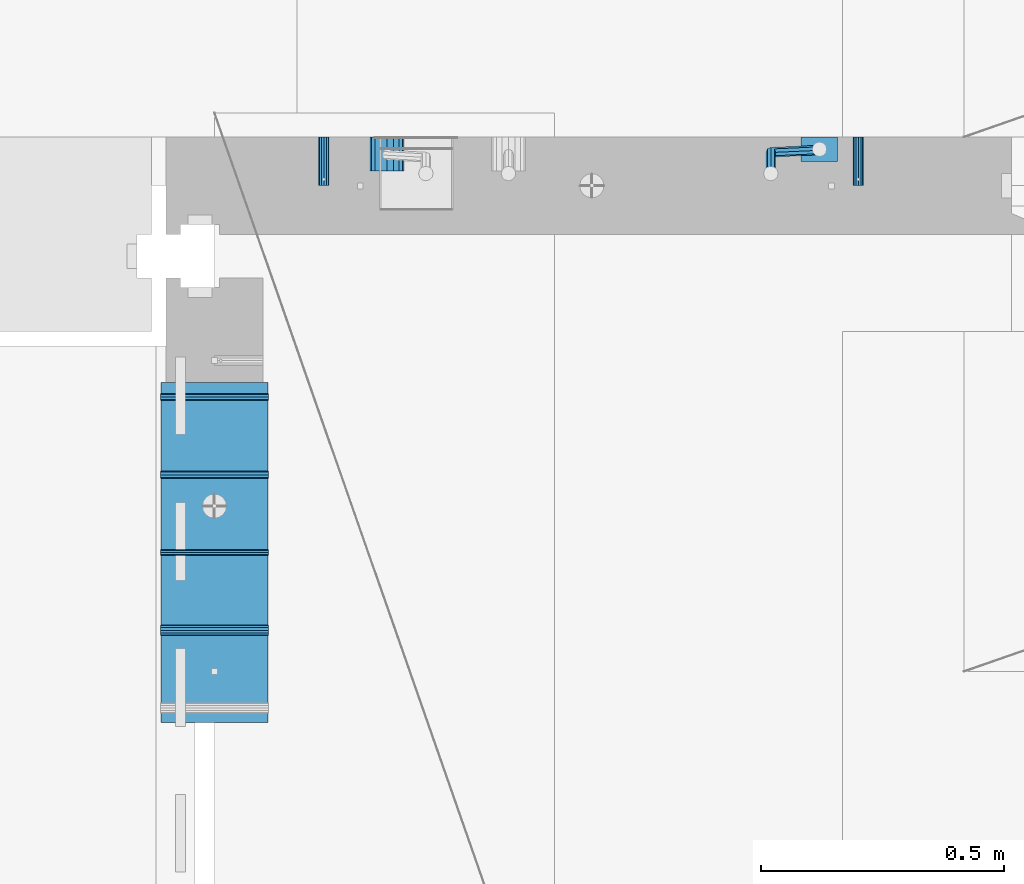
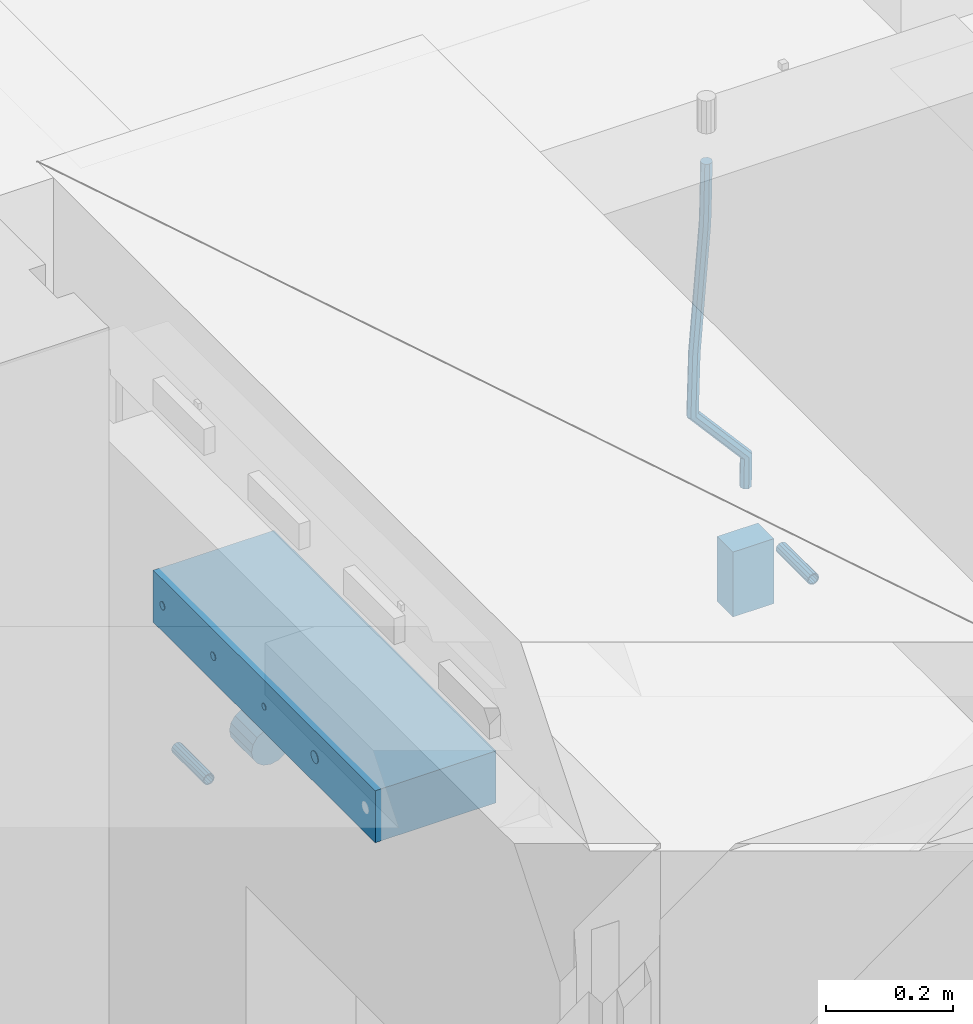
# One storey, part 143 of 325: 10 beams, 4 elements without a shape of their own.
"""IFC2X3 building model written with IfcOpenShell, lengths in millimetres."""

from ifc_helpers import new_model, si_unit, frame, origin_with_axes, place, context, subcontext, project, spatial, faceted_brep, material, type_object, element, aggregate, save


model = new_model("IFC2X3")

# Units and contexts
model_context = context("Model", 3, precision=1e-05, world=origin_with_axes())
body_context = subcontext(model_context, "Body", "Model", "MODEL_VIEW")
ifc_project = project(units=[si_unit("LENGTHUNIT", "METRE", prefix="MILLI"), si_unit("AREAUNIT", "SQUARE_METRE"), si_unit("VOLUMEUNIT", "CUBIC_METRE"), si_unit("MASSUNIT", "GRAM", prefix="KILO"), si_unit("TIMEUNIT", "SECOND"), si_unit("PLANEANGLEUNIT", "RADIAN"), si_unit("SOLIDANGLEUNIT", "STERADIAN"), si_unit("THERMODYNAMICTEMPERATUREUNIT", "DEGREE_CELSIUS"), si_unit("LUMINOUSINTENSITYUNIT", "LUMEN")], contexts=[model_context])

# Site, building, storey
site_placement = place(None, origin_with_axes())
site = spatial("IfcSite", under=ifc_project, at=site_placement, CompositionType="ELEMENT")
building_placement = place(site_placement, origin_with_axes())
building = spatial("IfcBuilding", under=site, at=building_placement, CompositionType="ELEMENT")
storey_placement = place(building_placement, origin_with_axes())
storey = spatial("IfcBuildingStorey", under=building, at=storey_placement, Name="1", CompositionType="ELEMENT", Elevation=0.0)

# Assemblies, beams
assembly_1_placement = place(storey_placement, origin_with_axes())
assembly_1 = element("IfcElementAssembly", 1, at=assembly_1_placement, inside=storey, AssemblyPlace="NOTDEFINED", PredefinedType="REINFORCEMENT_UNIT")
assembly_2_placement = place(assembly_1_placement, origin_with_axes())
assembly_2 = element("IfcElementAssembly", 2, at=assembly_2_placement, Name="Steel Assembly", AssemblyPlace="NOTDEFINED", PredefinedType="RIGID_FRAME")
ifc_material_1 = material(Name="STEEL/Steel_Undefined")
beam_type_1 = type_object("IfcBeamType", PredefinedType="NOTDEFINED")
beam_1_placement = place(assembly_2_placement, frame((26834.9999668009, 17080.0, 83555.0), z_axis=(-1.0, 3.00000001838171e-08, 0.0), x_axis=(0.0, -1.0, 0.0)))
beam_1 = element("IfcBeam", 3, at=beam_1_placement, type_object=beam_type_1, material=ifc_material_1, Name="M16", context=body_context, shape_type="Brep", body=[
    faceted_brep([(0.0, -8.49999999999272, -1.45519152283669e-11), (0.0, -7.36121593215648, 4.24999999998545), (100.000000000262, -7.36121593215648, 4.24999999998545), (100.000000000262, -8.49999999999272, -1.45519152283669e-11), (0.0, -4.24999999998545, 7.36121593216376), (100.000000000262, -4.24999999998545, 7.36121593216376), (0.0, 1.45519152283669e-11, 8.49999999998545), (100.000000000262, 1.45519152283669e-11, 8.49999999998545), (0.0, 4.25000000001455, 7.36121593216376), (100.000000000262, 4.25000000001455, 7.36121593216376), (0.0, 7.36121593217104, 4.24999999998545), (100.000000000262, 7.36121593217104, 4.24999999998545), (0.0, 8.50000000000728, 0.0), (100.000000000262, 8.50000000000728, 0.0), (0.0, 7.36121593217104, -4.25000000001455), (100.000000000262, 7.36121593217104, -4.25000000001455), (0.0, 4.25000000000728, -7.36121593219286), (100.000000000262, 4.25000000000728, -7.36121593219286), (0.0, 7.27595761418343e-12, -8.5), (100.000000000262, 7.27595761418343e-12, -8.5), (0.0, -4.24999999999272, -7.36121593217831), (100.000000000262, -4.24999999999272, -7.36121593217831), (0.0, -7.36121593215648, -4.25), (100.000000000262, -7.36121593215648, -4.25), (0.0, -10.4999999999927, -1.45519152283669e-11), (0.0, -9.09326673972828, -5.25000000001455), (100.000000000262, -9.09326673972828, -5.25000000001455), (100.000000000262, -10.4999999999927, -1.45519152283669e-11), (0.0, -5.24999999998545, -9.09326673974283), (100.000000000262, -5.24999999998545, -9.09326673974283), (0.0, 7.27595761418343e-12, -10.5), (100.000000000262, 7.27595761418343e-12, -10.5), (0.0, 5.25000000001455, -9.09326673975738), (100.000000000262, 5.25000000001455, -9.09326673975738), (0.0, 9.09326673975011, -5.25000000001455), (100.000000000262, 9.09326673975011, -5.25000000001455), (0.0, 10.5000000000073, -1.45519152283669e-11), (100.000000000262, 10.5000000000073, -1.45519152283669e-11), (0.0, 9.09326673975011, 5.25), (100.000000000262, 9.09326673975011, 5.25), (0.0, 5.25000000000728, 9.09326673972828), (100.000000000262, 5.25000000000728, 9.09326673972828), (0.0, 1.45519152283669e-11, 10.4999999999854), (100.000000000262, 1.45519152283669e-11, 10.4999999999854), (0.0, -5.24999999999272, 9.09326673972828), (100.000000000262, -5.24999999999272, 9.09326673972828), (0.0, -9.09326673972828, 5.24999999998545), (100.000000000262, -9.09326673972828, 5.24999999998545)], [[[0, 1, 2, 3]], [[1, 4, 5, 2]], [[4, 6, 7, 5]], [[6, 8, 9, 7]], [[8, 10, 11, 9]], [[10, 12, 13, 11]], [[12, 14, 15, 13]], [[14, 16, 17, 15]], [[16, 18, 19, 17]], [[18, 20, 21, 19]], [[20, 22, 23, 21]], [[22, 0, 3, 23]], [[24, 25, 26, 27]], [[25, 28, 29, 26]], [[28, 30, 31, 29]], [[30, 32, 33, 31]], [[32, 34, 35, 33]], [[34, 36, 37, 35]], [[36, 38, 39, 37]], [[38, 40, 41, 39]], [[40, 42, 43, 41]], [[42, 44, 45, 43]], [[44, 46, 47, 45]], [[46, 24, 27, 47]], [[29, 31, 33, 35, 37, 39, 41, 43, 45, 47, 27, 26], [5, 7, 9, 11, 13, 15, 17, 19, 21, 23, 3, 2]], [[46, 44, 42, 40, 38, 36, 34, 32, 30, 28, 25, 24], [22, 20, 18, 16, 14, 12, 10, 8, 6, 4, 1, 0]]]),
])
aggregate(assembly_2, [beam_1])
assembly_3_placement = place(assembly_1_placement, origin_with_axes())
assembly_3 = element("IfcElementAssembly", 4, at=assembly_3_placement, Name="Steel Assembly", AssemblyPlace="NOTDEFINED", PredefinedType="RIGID_FRAME")
beam_2_placement = place(assembly_3_placement, frame((27934.9999668009, 17080.0, 83555.0), z_axis=(1.0, 0.0, 0.0), x_axis=(0.0, -1.0, 0.0)))
beam_2 = element("IfcBeam", 5, at=beam_2_placement, type_object=beam_type_1, material=ifc_material_1, Name="M16", context=body_context, shape_type="Brep", body=[
    faceted_brep([(0.0, -8.49999999999272, -1.45519152283669e-11), (0.0, -7.36121593215648, 4.24999999998545), (100.000000000262, -7.36121593215648, 4.24999999998545), (100.000000000262, -8.49999999999272, -1.45519152283669e-11), (0.0, -4.24999999998545, 7.36121593216376), (100.000000000262, -4.24999999998545, 7.36121593216376), (0.0, 1.45519152283669e-11, 8.49999999998545), (100.000000000262, 1.45519152283669e-11, 8.49999999998545), (0.0, 4.25000000001455, 7.36121593216376), (100.000000000262, 4.25000000001455, 7.36121593216376), (0.0, 7.36121593217104, 4.24999999998545), (100.000000000262, 7.36121593217104, 4.24999999998545), (0.0, 8.50000000000728, 0.0), (100.000000000262, 8.50000000000728, 0.0), (0.0, 7.36121593217104, -4.25000000001455), (100.000000000262, 7.36121593217104, -4.25000000001455), (0.0, 4.25000000000728, -7.36121593219286), (100.000000000262, 4.25000000000728, -7.36121593219286), (0.0, 7.27595761418343e-12, -8.5), (100.000000000262, 7.27595761418343e-12, -8.5), (0.0, -4.24999999999272, -7.36121593217831), (100.000000000262, -4.24999999999272, -7.36121593217831), (0.0, -7.36121593215648, -4.25), (100.000000000262, -7.36121593215648, -4.25), (0.0, -10.4999999999927, -1.45519152283669e-11), (0.0, -9.09326673972828, -5.25000000001455), (100.000000000262, -9.09326673972828, -5.25000000001455), (100.000000000262, -10.4999999999927, -1.45519152283669e-11), (0.0, -5.24999999998545, -9.09326673974283), (100.000000000262, -5.24999999998545, -9.09326673974283), (0.0, 7.27595761418343e-12, -10.5), (100.000000000262, 7.27595761418343e-12, -10.5), (0.0, 5.25000000001455, -9.09326673975738), (100.000000000262, 5.25000000001455, -9.09326673975738), (0.0, 9.09326673975011, -5.25000000001455), (100.000000000262, 9.09326673975011, -5.25000000001455), (0.0, 10.5000000000073, -1.45519152283669e-11), (100.000000000262, 10.5000000000073, -1.45519152283669e-11), (0.0, 9.09326673975011, 5.25), (100.000000000262, 9.09326673975011, 5.25), (0.0, 5.25000000000728, 9.09326673972828), (100.000000000262, 5.25000000000728, 9.09326673972828), (0.0, 1.45519152283669e-11, 10.4999999999854), (100.000000000262, 1.45519152283669e-11, 10.4999999999854), (0.0, -5.24999999999272, 9.09326673972828), (100.000000000262, -5.24999999999272, 9.09326673972828), (0.0, -9.09326673972828, 5.24999999998545), (100.000000000262, -9.09326673972828, 5.24999999998545)], [[[0, 1, 2, 3]], [[1, 4, 5, 2]], [[4, 6, 7, 5]], [[6, 8, 9, 7]], [[8, 10, 11, 9]], [[10, 12, 13, 11]], [[12, 14, 15, 13]], [[14, 16, 17, 15]], [[16, 18, 19, 17]], [[18, 20, 21, 19]], [[20, 22, 23, 21]], [[22, 0, 3, 23]], [[24, 25, 26, 27]], [[25, 28, 29, 26]], [[28, 30, 31, 29]], [[30, 32, 33, 31]], [[32, 34, 35, 33]], [[34, 36, 37, 35]], [[36, 38, 39, 37]], [[38, 40, 41, 39]], [[40, 42, 43, 41]], [[42, 44, 45, 43]], [[44, 46, 47, 45]], [[46, 24, 27, 47]], [[29, 31, 33, 35, 37, 39, 41, 43, 45, 47, 27, 26], [5, 7, 9, 11, 13, 15, 17, 19, 21, 23, 3, 2]], [[46, 44, 42, 40, 38, 36, 34, 32, 30, 28, 25, 24], [22, 20, 18, 16, 14, 12, 10, 8, 6, 4, 1, 0]]]),
])
aggregate(assembly_3, [beam_2])
ifc_material_2 = material()
beam_type_2 = type_object("IfcBeamType", Name="D20", PredefinedType="NOTDEFINED")
beam_3_placement = place(assembly_1_placement, frame((27854.9999105249, 17055.0000022791, 83717.5), z_axis=(0.00020576299992186, -0.999642804629538, -0.0267249099901004), x_axis=(-4.30000201928125e-08, -0.0267249099948059, 0.999642825806181)))
beam_3 = element("IfcBeam", 6, at=beam_3_placement, type_object=beam_type_2, material=ifc_material_2, Name="JM20", ObjectType="D20", context=body_context, shape_type="Brep", body=[
    faceted_brep([(0.0, -10.0, 0.0), (-4.19531716033816e-08, -7.07106781186667, -7.07106781187031), (56.7763266096008, -7.0710677961506, -7.07106780607137), (56.776326613719, -9.99999998428393, 5.79166226089001e-09), (0.0, 0.0, -10.0), (56.7763266062684, 1.57124304678291e-08, -9.99999999421198), (4.196772351861e-08, 7.07106781186303, -7.07106781186667), (56.7763266056718, 7.07106782757546, -7.07106780607137), (0.0, 10.0, 0.0), (56.7763266081893, 10.0000000157124, 5.78802428208292e-09), (4.196772351861e-08, 7.07106781185939, 7.07106781185939), (56.7763266123075, 7.07106782757546, 7.07106781765469), (0.0, 0.0, 10.0), (56.7763266156253, 1.57160684466362e-08, 10.000000005788), (-4.19531716033816e-08, -7.07106781187031, 7.07106781185939), (56.7763266162219, -7.0710677961506, 7.07106781765469), (63.6581603578234, -7.07106779424794, -7.07106780537288), (64.7072452169814, -9.99999998209023, 6.59565557725728e-09), (61.0471495110105, 1.68947735801339e-08, -9.99999999377178), (58.4037074191001, 7.07106782802657, -7.0710678059113), (57.2763266081893, 10.0000000158543, 5.8389559853822e-09), (58.3254114673327, 7.07106782800838, 7.07106781781476), (60.9364223141602, 1.68656697496772e-08, 10.0000000062173), (63.579864406056, -7.07106779426613, 7.07106781834591), (68.8701191545988, -2.57766839202304, -7.00411221178365), (70.7137287347432, -4.82161494479442, 0.0771624871558743), (64.2816584837856, 2.78857553168928, -9.95844777191087), (59.6362047528673, 8.13364391482901, -7.05523448991153), (57.6550017540285, 10.3264681903675, 0.00486466808797559), (59.498611334202, 8.08252163759607, 7.0861393670275), (64.0870720050007, 2.71627771388376, 10.0404749271547), (68.7325257359189, -2.62879066925598, 7.13726164515538), (178.477093426045, 91.9180733962858, -5.59604274872618), (180.320703006204, 89.6741268435107, 1.48523195021698), (173.888632755246, 97.2843173199981, -8.5503783088534), (169.243179024328, 102.629385703138, -5.64716502685769), (167.261976025489, 104.822209978673, 1.41293413114181), (169.105585605663, 102.578263425905, 8.49420883008133), (173.694046276447, 97.2120195021926, 11.4485443902158), (178.33950000738, 91.8669511190528, 8.54533110821285), (179.709754584241, 92.9807907214599, -5.58020732815203), (180.699378152058, 90.0005950180312, 1.49009661246237), (177.123184081313, 100.072929348953, -8.50882554290365), (174.45484456385, 107.12253227874, -5.58021320060288), (173.267813132159, 110.000037723905, 1.49008830756429), (174.257436699947, 107.019842020472, 8.56039224817505), (176.844007202875, 99.9277033929829, 11.489010462923), (179.512346720367, 92.8781004631965, 8.56039812062227), (181.337040869024, 92.980797297354, -5.54839927738067), (181.199282661197, 90.0005970381535, 1.49986808792164), (181.393247249376, 100.072946604345, -8.42535996753213), (181.334976866914, 107.122560081465, -5.44572942864761), (181.196363721407, 110.0000697633, 1.64506518044436), (181.058605513594, 107.019869504104, 8.69333254575031), (181.002399133256, 99.927720197109, 11.5702932358981), (181.060669515704, 92.8781067199889, 8.59066269701725), (299.223992607163, 92.9812736804197, -3.24410028499551), (299.086234399336, 90.0010734212192, 3.80416708029952), (299.280198987515, 100.073422987411, -6.12106097514697), (299.221928605053, 107.123036464531, -3.14143043626973), (299.083315459546, 110.000546146366, 3.94936417282952), (298.945557251733, 107.020345887166, 10.9976315381282), (298.889350871395, 99.9281965801747, 13.8745922282797), (298.947621253843, 92.8785831030582, 10.8949616894024), (300.386756296284, 92.981278379164, -3.22137211061272), (299.976126552065, 90.0010770172848, 3.82156152099924), (300.554296041882, 100.073428136056, -6.09615660265263), (300.380603278143, 107.123041146755, -3.11878218858328), (299.967424870352, 110.000549719065, 3.96664558009434), (299.556795126133, 107.02034835719, 11.0095792117063), (299.389255380534, 99.928198600297, 13.8843637037498), (299.562948144274, 92.8785855896022, 10.9069892896769), (301.544281676513, 92.9813017552551, -3.10880675039516), (300.862009695906, 90.0010949075913, 3.90771060844054), (301.822653224983, 100.073453750381, -5.97281323097559), (301.534058063582, 107.123064440639, -3.00661267970645), (300.847551323837, 110.00056749312, 4.05223484920498), (300.165279343215, 107.020360645456, 11.0687522080407), (299.886907794746, 99.9282086503299, 13.9327586886211), (300.175502956146, 92.8785979600798, 10.966558137352), (567.278511684155, 92.9866682274078, 22.7329327341504), (566.596239703533, 90.006461379744, 29.7494500929861), (567.556883232639, 100.07882022253, 19.8689262535663), (567.268288071238, 107.128430912788, 22.8351268048391), (566.581781331479, 110.005933965269, 29.8939743337432), (565.899509350842, 107.025727117609, 36.9104916925789), (565.621137802387, 99.9335751224789, 39.774498173163), (565.909732963788, 92.8839644322252, 36.8082976218939), (567.849821402968, 92.9866797649374, 22.7884906384425), (567.44171451818, 90.0064784540082, 29.8316696094516), (568.054535646821, 100.078830272563, 19.9173212384412), (567.935938422117, 107.128444395908, 22.9000535040977), (567.563502374614, 110.005953791013, 29.9894433271184), (567.155395489812, 107.02575248008, 37.0326222981275), (566.950681245959, 99.9336019724578, 39.9037916981324), (567.069278470677, 92.8839878491162, 36.9210594324722), (568.423726556895, 92.9791958346468, 22.7961287491635), (568.29103028799, 89.9954030699082, 29.8429731634351), (568.554448874231, 100.072311223696, 19.923974589703), (568.6066218794, 107.119698441627, 22.9089796384433), (568.549683333578, 109.993093635469, 30.0025684215834), (568.416987064673, 107.009300870726, 37.049412835855), (568.286264747338, 99.9161854816812, 39.9215669953082), (568.234091742183, 92.8687982637566, 36.9365619465716), (589.912346713812, 92.6989764740647, 23.0821210580361), (589.779650444907, 89.7151837093297, 30.1289654723041), (590.043069031148, 99.7920918631135, 20.2099668985829), (590.095242036332, 106.839479081038, 23.1949719473196), (590.038303490495, 109.712874274886, 30.2885607304524), (589.905607221604, 106.729081510144, 37.3354051447241), (589.774884904284, 99.635966121099, 40.2075593041845), (589.7227118991, 92.5885789031709, 37.2225542554443), (590.547316919852, 92.6906962334651, 23.0905718842878), (590.439710196675, 89.7065762919956, 30.1377502156283), (590.620740976068, 99.7845588125092, 20.2176551415687), (590.616971548981, 106.832675539939, 23.2019156517927), (590.538216717905, 109.706355226012, 30.2952140817215), (590.430609994743, 106.722235284546, 37.342392413062), (590.357185938541, 99.6283727054979, 40.2153091557811), (590.360955365599, 92.5802559780714, 37.2310486455572), (591.182340840722, 92.6925634598811, 23.098834823104), (591.099825574536, 89.7085444738077, 30.1463496818142), (591.198462138229, 99.7862445059, 20.2251484999833), (591.138745829696, 106.834205462263, 23.2086571865184), (591.038172918692, 109.707846387795, 30.3016619575938), (590.955657652521, 106.723827401722, 37.3491768163003), (590.939536354999, 99.6301463557029, 40.222863139421), (590.999252663547, 92.5821853993439, 37.2393544528895), (691.203141317135, 92.9908263617035, 24.3962092481088), (691.120626050979, 90.0068073756338, 31.4437241068154), (691.219262614657, 100.08450740773, 21.5225229249845), (691.159546306109, 107.132468364089, 24.5060316115232), (691.05897339512, 110.006109289625, 31.5990363825986), (690.976458128949, 107.022090303552, 38.6465512412979), (690.960336831427, 99.928409257529, 41.5202375644258), (691.020053139975, 92.88044830117, 38.5367288778907)], [[[0, 1, 2, 3]], [[1, 4, 5, 2]], [[4, 6, 7, 5]], [[6, 8, 9, 7]], [[8, 10, 11, 9]], [[10, 12, 13, 11]], [[12, 14, 15, 13]], [[14, 0, 3, 15]], [[14, 12, 10, 8, 6, 4, 1, 0]], [[3, 2, 16, 17]], [[2, 5, 18, 16]], [[5, 7, 19, 18]], [[7, 9, 20, 19]], [[9, 11, 21, 20]], [[11, 13, 22, 21]], [[13, 15, 23, 22]], [[15, 3, 17, 23]], [[17, 16, 24, 25]], [[16, 18, 26, 24]], [[18, 19, 27, 26]], [[19, 20, 28, 27]], [[20, 21, 29, 28]], [[21, 22, 30, 29]], [[22, 23, 31, 30]], [[23, 17, 25, 31]], [[25, 24, 32, 33]], [[24, 26, 34, 32]], [[26, 27, 35, 34]], [[27, 28, 36, 35]], [[28, 29, 37, 36]], [[29, 30, 38, 37]], [[30, 31, 39, 38]], [[31, 25, 33, 39]], [[33, 32, 40, 41]], [[32, 34, 42, 40]], [[34, 35, 43, 42]], [[35, 36, 44, 43]], [[36, 37, 45, 44]], [[37, 38, 46, 45]], [[38, 39, 47, 46]], [[39, 33, 41, 47]], [[41, 40, 48, 49]], [[40, 42, 50, 48]], [[42, 43, 51, 50]], [[43, 44, 52, 51]], [[44, 45, 53, 52]], [[45, 46, 54, 53]], [[46, 47, 55, 54]], [[47, 41, 49, 55]], [[49, 48, 56, 57]], [[48, 50, 58, 56]], [[50, 51, 59, 58]], [[51, 52, 60, 59]], [[52, 53, 61, 60]], [[53, 54, 62, 61]], [[54, 55, 63, 62]], [[55, 49, 57, 63]], [[57, 56, 64, 65]], [[56, 58, 66, 64]], [[58, 59, 67, 66]], [[59, 60, 68, 67]], [[60, 61, 69, 68]], [[61, 62, 70, 69]], [[62, 63, 71, 70]], [[63, 57, 65, 71]], [[65, 64, 72, 73]], [[64, 66, 74, 72]], [[66, 67, 75, 74]], [[67, 68, 76, 75]], [[68, 69, 77, 76]], [[69, 70, 78, 77]], [[70, 71, 79, 78]], [[71, 65, 73, 79]], [[73, 72, 80, 81]], [[72, 74, 82, 80]], [[74, 75, 83, 82]], [[75, 76, 84, 83]], [[76, 77, 85, 84]], [[77, 78, 86, 85]], [[78, 79, 87, 86]], [[79, 73, 81, 87]], [[81, 80, 88, 89]], [[80, 82, 90, 88]], [[82, 83, 91, 90]], [[83, 84, 92, 91]], [[84, 85, 93, 92]], [[85, 86, 94, 93]], [[86, 87, 95, 94]], [[87, 81, 89, 95]], [[89, 88, 96, 97]], [[88, 90, 98, 96]], [[90, 91, 99, 98]], [[91, 92, 100, 99]], [[92, 93, 101, 100]], [[93, 94, 102, 101]], [[94, 95, 103, 102]], [[95, 89, 97, 103]], [[97, 96, 104, 105]], [[96, 98, 106, 104]], [[98, 99, 107, 106]], [[99, 100, 108, 107]], [[100, 101, 109, 108]], [[101, 102, 110, 109]], [[102, 103, 111, 110]], [[103, 97, 105, 111]], [[105, 104, 112, 113]], [[104, 106, 114, 112]], [[106, 107, 115, 114]], [[107, 108, 116, 115]], [[108, 109, 117, 116]], [[109, 110, 118, 117]], [[110, 111, 119, 118]], [[111, 105, 113, 119]], [[113, 112, 120, 121]], [[112, 114, 122, 120]], [[114, 115, 123, 122]], [[115, 116, 124, 123]], [[116, 117, 125, 124]], [[117, 118, 126, 125]], [[118, 119, 127, 126]], [[119, 113, 121, 127]], [[121, 120, 128, 129]], [[120, 122, 130, 128]], [[122, 123, 131, 130]], [[123, 124, 132, 131]], [[124, 125, 133, 132]], [[125, 126, 134, 133]], [[126, 127, 135, 134]], [[127, 121, 129, 135]], [[130, 131, 132, 133, 134, 135, 129, 128]]]),
])
beam_type_3 = type_object("IfcBeamType", Name="D70", PredefinedType="NOTDEFINED")
beam_4_placement = place(assembly_1_placement, frame((26964.9999105288, 17080.0000022791, 83555.0), z_axis=(0.0, 0.0, 1.0), x_axis=(0.0, -1.0, 0.0)))
beam_4 = element("IfcBeam", 7, at=beam_4_placement, type_object=beam_type_3, material=ifc_material_2, ObjectType="D70", context=body_context, shape_type="Brep", body=[
    faceted_brep([(0.0, -35.0, 0.0), (0.0, -32.3357836378964, -13.3939201327739), (70.0, -32.3357836378964, -13.3939201327739), (70.0, -35.0, 0.0), (0.0, -24.7487373415279, -24.7487373415352), (70.0, -24.7487373415279, -24.7487373415352), (0.0, -13.3939201327776, -32.3357836379), (70.0, -13.3939201327776, -32.3357836379), (0.0, 0.0, -35.0), (70.0, 0.0, -35.0), (0.0, 13.3939201327776, -32.3357836379), (70.0, 13.3939201327776, -32.3357836379), (0.0, 24.7487373415279, -24.7487373415352), (70.0, 24.7487373415279, -24.7487373415352), (0.0, 32.3357836378964, -13.3939201327739), (70.0, 32.3357836378964, -13.3939201327739), (0.0, 35.0, 0.0), (70.0, 35.0, 0.0), (0.0, 32.3357836378964, 13.3939201327739), (70.0, 32.3357836378964, 13.3939201327739), (0.0, 24.7487373415279, 24.7487373415352), (70.0, 24.7487373415279, 24.7487373415352), (0.0, 13.3939201327776, 32.3357836379), (70.0, 13.3939201327776, 32.3357836379), (0.0, 0.0, 35.0), (70.0, 0.0, 35.0), (0.0, -13.3939201327776, 32.3357836379), (70.0, -13.3939201327776, 32.3357836379), (0.0, -24.7487373415279, 24.7487373415352), (70.0, -24.7487373415279, 24.7487373415352), (0.0, -32.3357836378964, 13.3939201327739), (70.0, -32.3357836378964, 13.3939201327739)], [[[0, 1, 2, 3]], [[1, 4, 5, 2]], [[4, 6, 7, 5]], [[6, 8, 9, 7]], [[8, 10, 11, 9]], [[10, 12, 13, 11]], [[12, 14, 15, 13]], [[14, 16, 17, 15]], [[16, 18, 19, 17]], [[18, 20, 21, 19]], [[20, 22, 23, 21]], [[22, 24, 25, 23]], [[24, 26, 27, 25]], [[26, 28, 29, 27]], [[28, 30, 31, 29]], [[30, 0, 3, 31]], [[5, 7, 9, 11, 13, 15, 17, 19, 21, 23, 25, 27, 29, 31, 3, 2]], [[30, 28, 26, 24, 22, 20, 18, 16, 14, 12, 10, 8, 6, 4, 1, 0]]]),
])

# Assembly, beams
assembly_4_placement = place(storey_placement, origin_with_axes())
assembly_4 = element("IfcElementAssembly", 8, at=assembly_4_placement, inside=storey, AssemblyPlace="NOTDEFINED", PredefinedType="REINFORCEMENT_UNIT")
ifc_material_3 = material()
beam_type_4 = type_object("IfcBeamType", Name="D12", PredefinedType="NOTDEFINED")
beam_5_placement = place(assembly_4_placement, frame((26720.9994161083, 16225.0, 84270.0), z_axis=(0.0, -1.0, 0.0), x_axis=(-1.0, 3.00000001838171e-08, 0.0)))
beam_5 = element("IfcBeam", 9, at=beam_5_placement, type_object=beam_type_4, material=ifc_material_3, Name="12", ObjectType="D12", context=body_context, shape_type="Brep", body=[
    faceted_brep([(0.0, -6.0, -1.45519152283669e-11), (0.0, -4.24264068712, -4.24264068713819), (222.000077784061, -4.24264068712364, -4.24264068712), (222.000077784061, -6.0, 0.0), (3.63797880709171e-12, 0.0, -6.0000000000291), (222.000077784061, 0.0, -6.0), (0.0, 4.24264068712, -4.24264068713819), (222.000077784061, 4.24264068712364, -4.24264068712), (0.0, 6.0, -1.45519152283669e-11), (222.000077784061, 6.0, 0.0), (0.0, 4.24264068712, 4.24264068709454), (222.000077784061, 4.24264068712364, 4.24264068712), (0.0, 0.0, 5.99999999998545), (222.000077784061, 0.0, 6.0), (0.0, -4.24264068712, 4.24264068709454), (222.000077784061, -4.24264068712364, 4.24264068712)], [[[0, 1, 2, 3]], [[1, 4, 5, 2]], [[4, 6, 7, 5]], [[6, 8, 9, 7]], [[8, 10, 11, 9]], [[10, 12, 13, 11]], [[12, 14, 15, 13]], [[14, 0, 3, 15]], [[5, 7, 9, 11, 13, 15, 3, 2]], [[14, 12, 10, 8, 6, 4, 1, 0]]]),
])
beam_type_5 = type_object("IfcBeamType", Name="D15", PredefinedType="NOTDEFINED")
beam_6_placement = place(assembly_4_placement, frame((26720.9994161083, 16544.9998474121, 84270.0), z_axis=(0.0, -1.0, 0.0), x_axis=(-1.0, 3.00000001838171e-08, 0.0)))
beam_6 = element("IfcBeam", 10, at=beam_6_placement, type_object=beam_type_5, material=ifc_material_3, Name="15", ObjectType="D15", context=body_context, shape_type="Brep", body=[
    faceted_brep([(0.0, -7.5, 0.0), (0.0, -5.30330085889727, -5.30330085890091), (222.000077784061, -5.30330085889727, -5.30330085890091), (222.000077784061, -7.5, 0.0), (0.0, 1.45519152283669e-11, -7.5), (222.000077784061, 0.0, -7.5), (0.0, 5.30330085889727, -5.30330085890091), (222.000077784061, 5.30330085889727, -5.30330085890091), (0.0, 7.5, 0.0), (222.000077784061, 7.5, 0.0), (0.0, 5.30330085889727, 5.30330085890091), (222.000077784061, 5.30330085889727, 5.30330085890091), (0.0, 1.45519152283669e-11, 7.5), (222.000077784061, 0.0, 7.5), (0.0, -5.30330085889727, 5.30330085890091), (222.000077784061, -5.30330085889727, 5.30330085890091)], [[[0, 1, 2, 3]], [[1, 4, 5, 2]], [[4, 6, 7, 5]], [[6, 8, 9, 7]], [[8, 10, 11, 9]], [[10, 12, 13, 11]], [[12, 14, 15, 13]], [[14, 0, 3, 15]], [[5, 7, 9, 11, 13, 15, 3, 2]], [[14, 12, 10, 8, 6, 4, 1, 0]]]),
])
beam_7_placement = place(assembly_4_placement, frame((26720.9994161083, 16385.0, 84270.0), z_axis=(0.0, -1.0, 0.0), x_axis=(-1.0, 3.00000001838171e-08, 0.0)))
beam_7 = element("IfcBeam", 11, at=beam_7_placement, type_object=beam_type_5, material=ifc_material_3, Name="15", ObjectType="D15", context=body_context, shape_type="Brep", body=[
    faceted_brep([(0.0, -7.5, 0.0), (0.0, -5.30330085889727, -5.30330085890091), (222.000077784061, -5.30330085889727, -5.30330085890091), (222.000077784061, -7.5, 0.0), (0.0, 1.45519152283669e-11, -7.5), (222.000077784061, 0.0, -7.5), (0.0, 5.30330085889727, -5.30330085890091), (222.000077784061, 5.30330085889727, -5.30330085890091), (0.0, 7.5, 0.0), (222.000077784061, 7.5, 0.0), (0.0, 5.30330085889727, 5.30330085890091), (222.000077784061, 5.30330085889727, 5.30330085890091), (0.0, 1.45519152283669e-11, 7.5), (222.000077784061, 0.0, 7.5), (0.0, -5.30330085889727, 5.30330085890091), (222.000077784061, -5.30330085889727, 5.30330085890091)], [[[0, 1, 2, 3]], [[1, 4, 5, 2]], [[4, 6, 7, 5]], [[6, 8, 9, 7]], [[8, 10, 11, 9]], [[10, 12, 13, 11]], [[12, 14, 15, 13]], [[14, 0, 3, 15]], [[5, 7, 9, 11, 13, 15, 3, 2]], [[14, 12, 10, 8, 6, 4, 1, 0]]]),
])
beam_type_6 = type_object("IfcBeamType", Name="D22", PredefinedType="NOTDEFINED")
beam_8_placement = place(assembly_4_placement, frame((26720.9994161083, 16065.0, 84270.0), z_axis=(0.0, -1.0, 0.0), x_axis=(-1.0, 3.00000001838171e-08, 0.0)))
beam_8 = element("IfcBeam", 12, at=beam_8_placement, type_object=beam_type_6, material=ifc_material_3, Name="22", ObjectType="D22", context=body_context, shape_type="Brep", body=[
    faceted_brep([(0.0, -11.0, 0.0), (0.0, -9.52627944163396, -5.5), (222.000077784061, -9.52627944163396, -5.5), (222.000077784061, -11.0, 0.0), (0.0, -5.5, -9.52627944163032), (222.000077784061, -5.5, -9.52627944163032), (0.0, 0.0, -11.0), (222.000077784061, 0.0, -11.0), (0.0, 5.5, -9.52627944163032), (222.000077784061, 5.5, -9.52627944163032), (0.0, 9.52627944163396, -5.5), (222.000077784061, 9.52627944163396, -5.5), (0.0, 11.0, 0.0), (222.000077784061, 11.0, 0.0), (0.0, 9.52627944163396, 5.5), (222.000077784061, 9.52627944163396, 5.5), (0.0, 5.5, 9.52627944163032), (222.000077784061, 5.5, 9.52627944163032), (0.0, 0.0, 11.0), (222.000077784061, 0.0, 11.0), (0.0, -5.5, 9.52627944163032), (222.000077784061, -5.5, 9.52627944163032), (0.0, -9.52627944163396, 5.5), (222.000077784061, -9.52627944163396, 5.5)], [[[0, 1, 2, 3]], [[1, 4, 5, 2]], [[4, 6, 7, 5]], [[6, 8, 9, 7]], [[8, 10, 11, 9]], [[10, 12, 13, 11]], [[12, 14, 15, 13]], [[14, 16, 17, 15]], [[16, 18, 19, 17]], [[18, 20, 21, 19]], [[20, 22, 23, 21]], [[22, 0, 3, 23]], [[5, 7, 9, 11, 13, 15, 17, 19, 21, 23, 3, 2]], [[22, 20, 18, 16, 14, 12, 10, 8, 6, 4, 1, 0]]]),
])
beam_type_7 = type_object("IfcBeamType", PredefinedType="NOTDEFINED")
beam_9_placement = place(assembly_4_placement, frame((26719.9994161083, 16225.0, 84270.0), z_axis=(0.0, -1.0, 0.0), x_axis=(-1.0, 3.00000001838171e-08, 0.0)))
beam_9 = element("IfcBeam", 13, at=beam_9_placement, type_object=beam_type_7, material=ifc_material_3, context=body_context, shape_type="Brep", body=[
    faceted_brep([(0.0, 50.0, -350.0), (0.0, 50.0, 350.0), (220.000077784061, 50.0, 350.0), (220.000077784061, 50.0, -350.0), (0.0, -50.0, 350.0), (220.000077784061, -50.0, 350.0), (0.0, -50.0, -350.0), (220.000077784061, -50.0, -350.0)], [[[0, 1, 2, 3]], [[1, 4, 5, 2]], [[4, 6, 7, 5]], [[6, 0, 3, 7]], [[5, 7, 3, 2]], [[6, 4, 1, 0]]]),
])
aggregate(assembly_4, [beam_8, beam_5, beam_9, beam_6, beam_7])

# Beam
beam_type_8 = type_object("IfcBeamType", PredefinedType="NOTDEFINED")
beam_10_placement = place(assembly_1_placement, frame((27892.4999105288, 17055.0, 83555.0), z_axis=(0.0, 0.0, 1.0), x_axis=(-1.0, 3.00000001838171e-08, 0.0)))
beam_10 = element("IfcBeam", 14, at=beam_10_placement, type_object=beam_type_8, material=ifc_material_2, Name="WM1", context=body_context, shape_type="Brep", body=[
    faceted_brep([(0.0, 25.0, -62.5), (0.0, 25.0, 62.5), (75.0, 25.0, 62.5), (75.0, 25.0, -62.5), (0.0, -25.0, 62.5), (75.0, -25.0, 62.5), (0.0, -25.0, -62.5), (75.0, -25.0, -62.5)], [[[0, 1, 2, 3]], [[1, 4, 5, 2]], [[4, 6, 7, 5]], [[6, 0, 3, 7]], [[5, 7, 3, 2]], [[0, 6, 4, 1]]]),
])

aggregate(assembly_1, [assembly_2, assembly_3, beam_3, beam_10, beam_4])

save(model, "model.ifc")
